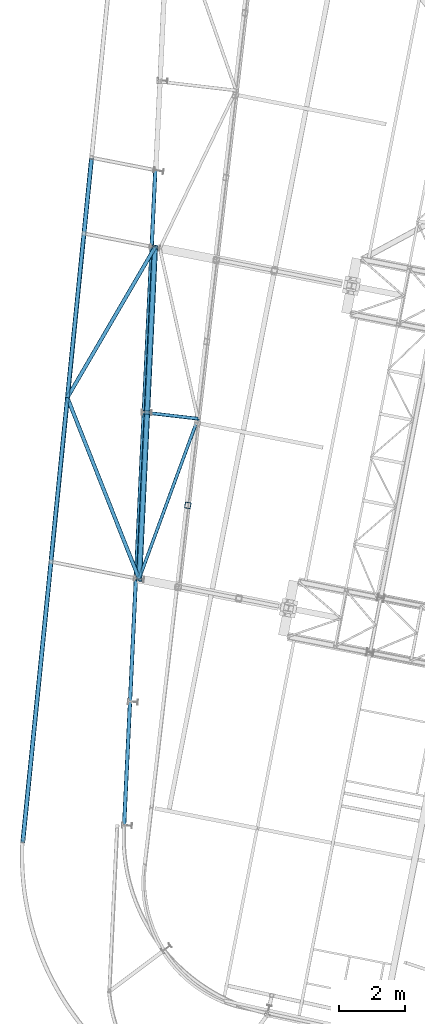
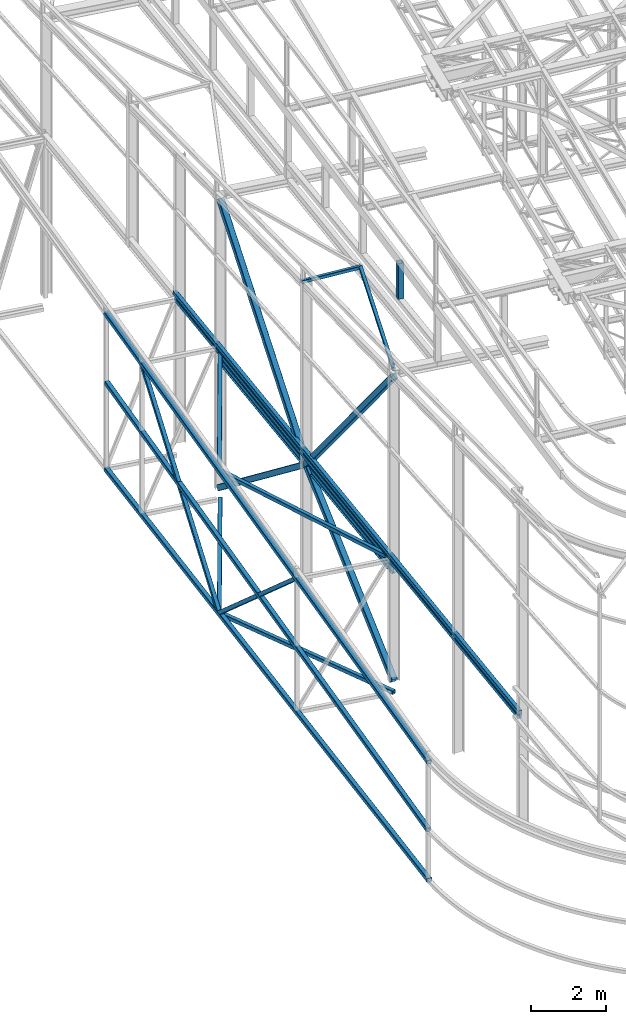
# One storey, part 42 of 215: 13 beams, 6 members, 19 elements without a shape of their own.
"""IFC2X3 building model written with IfcOpenShell, lengths in millimetres."""

from ifc_helpers import new_model, si_unit, frame, origin_with_axes, origin_2d_with_axis, place, context, subcontext, project, spatial, hollow_rectangle, i_section, extrude, clip, halfspace, material, type_object, element, aggregate, save


model = new_model("IFC2X3")

# Units and contexts
model_context = context("Model", 3, precision=1e-05, world=origin_with_axes())
body_context = subcontext(model_context, "Body", "Model", "MODEL_VIEW")
ifc_project = project(units=[si_unit("LENGTHUNIT", "METRE", prefix="MILLI"), si_unit("AREAUNIT", "SQUARE_METRE"), si_unit("VOLUMEUNIT", "CUBIC_METRE"), si_unit("MASSUNIT", "GRAM", prefix="KILO"), si_unit("TIMEUNIT", "SECOND"), si_unit("PLANEANGLEUNIT", "RADIAN"), si_unit("SOLIDANGLEUNIT", "STERADIAN"), si_unit("THERMODYNAMICTEMPERATUREUNIT", "DEGREE_CELSIUS"), si_unit("LUMINOUSINTENSITYUNIT", "LUMEN")], contexts=[model_context])

# Site, building, storey
site_placement = place(None, origin_with_axes())
site = spatial("IfcSite", under=ifc_project, at=site_placement, CompositionType="ELEMENT")
building_placement = place(site_placement, origin_with_axes())
building = spatial("IfcBuilding", under=site, at=building_placement, Name="Undefined", CompositionType="ELEMENT")
storey_placement = place(building_placement, origin_with_axes())
storey = spatial("IfcBuildingStorey", under=building, at=storey_placement, Name="Undefined", CompositionType="ELEMENT", Elevation=0.0)

# Assembly, beam
assembly_1_placement = place(storey_placement, origin_with_axes())
assembly_1 = element("IfcElementAssembly", 1, at=assembly_1_placement, inside=storey, Name="Steel Assembly", AssemblyPlace="NOTDEFINED", PredefinedType="RIGID_FRAME")
ifc_material_1 = material(Name="STEEL/S275JR")
beam_type_1 = type_object("IfcBeamType", Name="IPE240", PredefinedType="NOTDEFINED")
beam_1_placement = place(assembly_1_placement, frame((37702.395023757, 24081.8453887857, 3587.95465777144), z_axis=(-0.00276384299864547, -0.0580777589715231, 0.99830823651051), x_axis=(0.0474544460183351, 0.997179728385277, 0.0581434850224647)))
beam_1 = element("IfcBeam", 2, at=beam_1_placement, type_object=beam_type_1, material=ifc_material_1, Name="LISSE", ObjectType="IPE240", context=body_context, shape_type="SweptSolid", body=[
    extrude(i_section(OverallWidth=120.0, OverallDepth=240.0, WebThickness=6.199999809, FlangeThickness=9.800000191, FilletRadius=15.0, at=origin_2d_with_axis()), frame((10139.4064465862, -4.89457653130636e-14, 1.05020723293584e-12), z_axis=(-1.0, 0.0, 0.0), x_axis=(-6.93889390390723e-18, -1.0, -3.46944695195361e-18)), (0.0, 0.0, 1.0), 10139.4),
])
aggregate(assembly_1, [beam_1])

assembly_2_placement = place(storey_placement, origin_with_axes())
assembly_2 = element("IfcElementAssembly", 3, at=assembly_2_placement, inside=storey, Name="Steel Assembly", AssemblyPlace="NOTDEFINED", PredefinedType="RIGID_FRAME")
beam_type_2 = type_object("IfcBeamType", PredefinedType="NOTDEFINED")
beam_2_placement = place(assembly_2_placement, frame((37245.3550198465, 16578.5143878972, 3521.9789241944), z_axis=(-0.00279870499998948, -0.0583324129997587, 0.998293291995869), x_axis=(0.0475199150160084, 0.997161649335921, 0.0583995100196734)))
beam_2 = element("IfcBeam", 4, at=beam_2_placement, type_object=beam_type_2, material=ifc_material_1, Name="LISSE", context=body_context, shape_type="SweptSolid", body=[
    extrude(hollow_rectangle(XDim=120.0, YDim=120.0, WallThickness=5.0, InnerFilletRadius=5.0, OuterFilletRadius=10.0, at=origin_2d_with_axis()), frame((20005.568951686, -7.52018708256912e-12, 5.93563871329514e-13), z_axis=(-1.0, 0.0, 0.0), x_axis=(-6.93889390390723e-18, -1.0, -3.46944695195361e-18)), (0.0, 0.0, 1.0), 20005.6),
])
aggregate(assembly_2, [beam_2])

assembly_3_placement = place(storey_placement, origin_with_axes())
assembly_3 = element("IfcElementAssembly", 5, at=assembly_3_placement, inside=storey, Name="Steel Assembly", AssemblyPlace="NOTDEFINED", PredefinedType="RIGID_FRAME")
beam_3_placement = place(assembly_3_placement, frame((37244.8113143843, 16560.4333844096, 3680.22824974108), z_axis=(-0.00274567599890538, -0.0584633859767245, 0.998285777602509), x_axis=(0.0475021389989792, 0.997154973978577, 0.0585278109987426)))
beam_3 = element("IfcBeam", 6, at=beam_3_placement, type_object=beam_type_2, material=ifc_material_1, Name="LISSE", context=body_context, shape_type="SweptSolid", body=[
    extrude(hollow_rectangle(XDim=120.0, YDim=120.0, WallThickness=5.0, InnerFilletRadius=5.0, OuterFilletRadius=10.0, at=origin_2d_with_axis()), frame((20106.9030449298, -7.079022164791e-14, -1.39519666964917e-13), z_axis=(-1.0, 0.0, 0.0), x_axis=(-6.93889390390723e-18, -1.0, -3.46944695195361e-18)), (0.0, 0.0, 1.0), 20106.9),
])
aggregate(assembly_3, [beam_3])

assembly_4_placement = place(storey_placement, origin_with_axes())
assembly_4 = element("IfcElementAssembly", 7, at=assembly_4_placement, inside=storey, Name="Steel Assembly", AssemblyPlace="NOTDEFINED", PredefinedType="RIGID_FRAME")
beam_4_placement = place(assembly_4_placement, frame((35516.1942350972, 29589.8617573046, 4249.99303533058), z_axis=(0.86391141855058, -0.503643783737995, 0.0), x_axis=(0.502921216817885, 0.862671983687614, 0.0535471589806098)))
beam_4 = element("IfcBeam", 8, at=beam_4_placement, type_object=beam_type_2, material=ifc_material_1, context=body_context, shape_type="SweptSolid", body=[
    extrude(hollow_rectangle(XDim=120.0, YDim=120.0, WallThickness=5.0, InnerFilletRadius=5.0, OuterFilletRadius=10.0, at=origin_2d_with_axis()), frame((5302.3875490753, 5.28332760167328e-13, 3.76816913364588e-12), z_axis=(-1.0, 0.0, 0.0), x_axis=(-6.93889390390723e-18, -1.0, -3.46944695195361e-18)), (0.0, 0.0, 1.0), 5302.4),
])
aggregate(assembly_4, [beam_4])

assembly_5_placement = place(storey_placement, origin_with_axes())
assembly_5 = element("IfcElementAssembly", 9, at=assembly_5_placement, inside=storey, Name="Steel Assembly", AssemblyPlace="NOTDEFINED", PredefinedType="RIGID_FRAME")
beam_5_placement = place(assembly_5_placement, frame((37702.401727113, 24069.1858218941, 3944.51786385128), z_axis=(0.929752431547219, 0.368185301216702, 0.0), x_axis=(-0.367699031175966, 0.928524488444354, 0.0513779800245874)))
beam_5 = element("IfcBeam", 10, at=beam_5_placement, type_object=beam_type_2, material=ifc_material_1, context=body_context, shape_type="SweptSolid", body=[
    extrude(hollow_rectangle(XDim=120.0, YDim=120.0, WallThickness=5.0, InnerFilletRadius=5.0, OuterFilletRadius=10.0, at=origin_2d_with_axis()), frame((5945.64387417215, 0.0, 7.29676072179177e-12), z_axis=(-1.0, 0.0, 0.0), x_axis=(-6.93889390390723e-18, -1.0, -3.46944695195361e-18)), (0.0, 0.0, 1.0), 5945.6),
])
aggregate(assembly_5, [beam_5])

assembly_6_placement = place(storey_placement, origin_with_axes())
assembly_6 = element("IfcElementAssembly", 11, at=assembly_6_placement, inside=storey, Name="Steel Assembly", AssemblyPlace="NOTDEFINED", PredefinedType="RIGID_FRAME")
beam_6_placement = place(assembly_6_placement, frame((35516.1942349543, 29589.8617572934, -375.378507628906), z_axis=(0.86391141855058, -0.503643783737995, 0.0), x_axis=(0.5036437841731, 0.863911418296922, 0.0)))
beam_6 = element("IfcBeam", 12, at=beam_6_placement, type_object=beam_type_2, material=ifc_material_1, context=body_context, shape_type="SweptSolid", body=[
    extrude(hollow_rectangle(XDim=120.0, YDim=120.0, WallThickness=5.0, InnerFilletRadius=5.0, OuterFilletRadius=10.0, at=origin_2d_with_axis()), frame((5294.78032861947, 0.0, -5.87838703116569e-13), z_axis=(-1.0, 0.0, 0.0), x_axis=(-6.93889390390723e-18, -1.0, -3.46944695195361e-18)), (0.0, 0.0, 1.0), 5294.8),
])
aggregate(assembly_6, [beam_6])

assembly_7_placement = place(storey_placement, origin_with_axes())
assembly_7 = element("IfcElementAssembly", 13, at=assembly_7_placement, inside=storey, Name="Steel Assembly", AssemblyPlace="NOTDEFINED", PredefinedType="RIGID_FRAME")
beam_7_placement = place(assembly_7_placement, frame((37702.4017271117, 24069.1858218863, -375.378507632738), z_axis=(0.929752431547219, 0.368185301216702, 0.0), x_axis=(-0.36818530087438, 0.92975243168278, 0.0)))
beam_7 = element("IfcBeam", 14, at=beam_7_placement, type_object=beam_type_2, material=ifc_material_1, context=body_context, shape_type="SweptSolid", body=[
    extrude(hollow_rectangle(XDim=120.0, YDim=120.0, WallThickness=5.0, InnerFilletRadius=5.0, OuterFilletRadius=10.0, at=origin_2d_with_axis()), frame((5937.79133878312, 5.6843418860808e-14, 0.0), z_axis=(-1.0, 0.0, 0.0), x_axis=(-6.93889390390723e-18, -1.0, -3.46944695195361e-18)), (0.0, 0.0, 1.0), 5937.8),
])
aggregate(assembly_7, [beam_7])

assembly_8_placement = place(storey_placement, origin_with_axes())
assembly_8 = element("IfcElementAssembly", 15, at=assembly_8_placement, inside=storey, Name="Steel Assembly", AssemblyPlace="NOTDEFINED", PredefinedType="RIGID_FRAME")
beam_type_3 = type_object("IfcBeamType", PredefinedType="NOTDEFINED")
beam_8_placement = place(assembly_8_placement, frame((37784.1180891928, 29146.3516959011, 9870.42381029641), z_axis=(0.115203788960212, 0.992088860657365, -0.0498776459827747), x_axis=(0.993325216792512, -0.115347360975905, -6.30000004858045e-08)))
beam_8 = element("IfcBeam", 16, at=beam_8_placement, type_object=beam_type_3, material=ifc_material_1, context=body_context, shape_type="SweptSolid", body=[
    extrude(hollow_rectangle(XDim=100.0, YDim=100.0, WallThickness=5.0, InnerFilletRadius=5.0, OuterFilletRadius=10.0, at=origin_2d_with_axis()), frame((1716.90167054726, 1.3722649592389e-15, 4.55212574664582e-15), z_axis=(-1.0, 0.0, 0.0), x_axis=(-6.93889390390723e-18, -1.0, -3.46944695195361e-18)), (0.0, 0.0, 1.0), 1716.9),
])
aggregate(assembly_8, [beam_8])

assembly_9_placement = place(storey_placement, origin_with_axes())
assembly_9 = element("IfcElementAssembly", 17, at=assembly_9_placement, inside=storey, Name="Steel Assembly", AssemblyPlace="NOTDEFINED", PredefinedType="RIGID_FRAME")
beam_9_placement = place(assembly_9_placement, frame((39489.5598133644, 28948.3116191889, 9870.42370259191), z_axis=(0.938944613111395, -0.343871057040797, 0.0116494480013822), x_axis=(-0.344020222019175, -0.937708919052267, 0.0484981440027034)))
beam_9 = element("IfcBeam", 18, at=beam_9_placement, type_object=beam_type_3, material=ifc_material_1, context=body_context, shape_type="SweptSolid", body=[
    extrude(hollow_rectangle(XDim=100.0, YDim=100.0, WallThickness=5.0, InnerFilletRadius=5.0, OuterFilletRadius=10.0, at=origin_2d_with_axis()), frame((5191.06870020418, -1.78296912858725e-12, 4.44730936006799e-12), z_axis=(-1.0, 0.0, 0.0), x_axis=(-6.93889390390723e-18, -1.0, -3.46944695195361e-18)), (0.0, 0.0, 1.0), 5191.1),
])
aggregate(assembly_9, [beam_9])

# Assembly, member
assembly_10_placement = place(storey_placement, origin_with_axes())
assembly_10 = element("IfcElementAssembly", 19, at=assembly_10_placement, inside=storey, Name="Steel Assembly", AssemblyPlace="NOTDEFINED", PredefinedType="RIGID_FRAME")
member_type_1 = type_object("IfcMemberType", PredefinedType="NOTDEFINED")
member_1_placement = place(assembly_10_placement, frame((35516.2354425136, 29590.2715087666, -380.000192254633), z_axis=(-0.994981508328456, 0.10005897303303, 7.60000000037375e-08), x_axis=(-0.0757336799789731, -0.753092482790908, 0.653541216818548)))
member_1 = element("IfcMember", 20, at=member_1_placement, type_object=member_type_1, material=ifc_material_1, Name="LISSE", context=body_context, shape_type="SweptSolid", body=[
    extrude(hollow_rectangle(XDim=120.0, YDim=120.0, WallThickness=5.0, InnerFilletRadius=5.0, OuterFilletRadius=10.0, at=origin_2d_with_axis()), frame((6634.36296563795, -7.36562251817169e-13, 1.32184024394049e-13), z_axis=(-1.0, 0.0, 0.0), x_axis=(-6.93889390390723e-18, -1.0, -3.46944695195361e-18)), (0.0, 0.0, 1.0), 6634.4),
])
aggregate(assembly_10, [member_1])

assembly_11_placement = place(storey_placement, origin_with_axes())
assembly_11 = element("IfcElementAssembly", 21, at=assembly_11_placement, inside=storey, Name="Steel Assembly", AssemblyPlace="NOTDEFINED", PredefinedType="RIGID_FRAME")
member_2_placement = place(assembly_11_placement, frame((36018.6780823978, 34586.5397305908, 4544.18726639941), z_axis=(-0.994978168370554, 0.100092174037274, -3.40950000126771e-05), x_axis=(-0.0714409600094574, -0.710405871094048, -0.700156902092691)))
member_2 = element("IfcMember", 22, at=member_2_placement, type_object=member_type_1, material=ifc_material_1, Name="LISSE", context=body_context, shape_type="SweptSolid", body=[
    extrude(hollow_rectangle(XDim=120.0, YDim=120.0, WallThickness=5.0, InnerFilletRadius=5.0, OuterFilletRadius=10.0, at=origin_2d_with_axis()), frame((7032.97709762473, -7.80817310544438e-13, -3.54609552005987e-12), z_axis=(-1.0, 0.0, 0.0), x_axis=(-6.93889390390723e-18, -1.0, -3.46944695195361e-18)), (0.0, 0.0, 1.0), 7033.0),
])
aggregate(assembly_11, [member_2])

# Assembly, beam
assembly_12_placement = place(storey_placement, origin_with_axes())
assembly_12 = element("IfcElementAssembly", 23, at=assembly_12_placement, inside=storey, Name="Steel Assembly", AssemblyPlace="NOTDEFINED", PredefinedType="RIGID_FRAME")
beam_type_4 = type_object("IfcBeamType", PredefinedType="NOTDEFINED")
beam_10_placement = place(assembly_12_placement, frame((39183.2042802955, 26310.2501751328, 11749.0824556142), z_axis=(-0.981422412140383, 0.191859451027444, 0.0), x_axis=(0.0, 0.0, -1.0)))
beam_10 = element("IfcBeam", 24, at=beam_10_placement, type_object=beam_type_4, material=ifc_material_1, Name="MONTANT", context=body_context, shape_type="Clipping", body=[
    clip(extrude(hollow_rectangle(XDim=180.0, YDim=180.0, WallThickness=8.0, InnerFilletRadius=12.0, OuterFilletRadius=20.0, at=origin_2d_with_axis()), frame((1166.84780650014, 0.0, 0.0), z_axis=(-1.0, 0.0, 0.0), x_axis=(-6.93889390390723e-18, -1.0, -3.46944695195361e-18)), (0.0, 0.0, 1.0), 1166.8), halfspace(frame((1169.02037938846, -133.691974753034, 100.630765854497), z_axis=(-0.99875033817135, -0.0498277907891155, 0.00386694552461437), x_axis=(0.0, -0.0773735506072624, -0.997002173350904)), True)),
])
aggregate(assembly_12, [beam_10])

assembly_13_placement = place(storey_placement, origin_with_axes())
assembly_13 = element("IfcElementAssembly", 25, at=assembly_13_placement, inside=storey, Name="Steel Assembly", AssemblyPlace="NOTDEFINED", PredefinedType="RIGID_FRAME")
beam_type_5 = type_object("IfcBeamType", PredefinedType="NOTDEFINED")
beam_11_placement = place(assembly_13_placement, frame((34164.6279979949, 16103.0440502901, 1226.42910362387), z_axis=(-0.00585299100114405, -0.058084468011355, 0.998294514195174), x_axis=(0.0998883439531066, 0.993284579533696, 0.0583786159725937)))
beam_11 = element("IfcBeam", 26, at=beam_11_placement, type_object=beam_type_5, material=ifc_material_1, Name="LISSE", context=body_context, shape_type="SweptSolid", body=[
    extrude(hollow_rectangle(XDim=140.0, YDim=140.0, WallThickness=8.0, InnerFilletRadius=12.0, OuterFilletRadius=20.0, at=origin_2d_with_axis()), frame((20885.9053007552, 7.27560158180373e-12, -3.98160303286319e-14), z_axis=(-1.0, 0.0, 0.0), x_axis=(-6.93889390390723e-18, -1.0, -3.46944695195361e-18)), (0.0, 0.0, 1.0), 20885.9),
])
aggregate(assembly_13, [beam_11])

assembly_14_placement = place(storey_placement, origin_with_axes())
assembly_14 = element("IfcElementAssembly", 27, at=assembly_14_placement, inside=storey, Name="Steel Assembly", AssemblyPlace="NOTDEFINED", PredefinedType="RIGID_FRAME")
beam_12_placement = place(assembly_14_placement, frame((34158.6788035481, 16043.8873792673, -380.000192697401), z_axis=(0.0, 0.0, 1.0), x_axis=(0.100060559973715, 0.994981348738631, -3.79999999887618e-08)))
beam_12 = element("IfcBeam", 28, at=beam_12_placement, type_object=beam_type_5, material=ifc_material_1, Name="LISSE", context=body_context, shape_type="SweptSolid", body=[
    extrude(hollow_rectangle(XDim=140.0, YDim=140.0, WallThickness=8.0, InnerFilletRadius=12.0, OuterFilletRadius=20.0, at=origin_2d_with_axis()), frame((20945.2237454623, -2.21015460189945e-13, 0.0), z_axis=(-1.0, 0.0, 0.0), x_axis=(-6.93889390390723e-18, -1.0, -3.46944695195361e-18)), (0.0, 0.0, 1.0), 20945.2),
])
aggregate(assembly_14, [beam_12])

assembly_15_placement = place(storey_placement, origin_with_axes())
assembly_15 = element("IfcElementAssembly", 29, at=assembly_15_placement, inside=storey, Name="Steel Assembly", AssemblyPlace="NOTDEFINED", PredefinedType="RIGID_FRAME")
beam_13_placement = place(assembly_15_placement, frame((34159.0884629908, 16047.9608884652, 3452.64841673588), z_axis=(-0.00585213200252552, -0.0581915090251133, 0.998288285430819), x_axis=(0.099887760989917, 0.993278377899736, 0.0584850339940963)))
beam_13 = element("IfcBeam", 30, at=beam_13_placement, type_object=beam_type_5, material=ifc_material_1, Name="LISSE", context=body_context, shape_type="SweptSolid", body=[
    extrude(hollow_rectangle(XDim=140.0, YDim=140.0, WallThickness=8.0, InnerFilletRadius=12.0, OuterFilletRadius=20.0, at=origin_2d_with_axis()), frame((20993.6087199957, 2.2296368648553e-13, -4.54747350886464e-13), z_axis=(-1.0, 0.0, 0.0), x_axis=(-6.93889390390723e-18, -1.0, -3.46944695195361e-18)), (0.0, 0.0, 1.0), 20993.6),
])
aggregate(assembly_15, [beam_13])

# Assembly, member
assembly_16_placement = place(storey_placement, origin_with_axes())
assembly_16 = element("IfcElementAssembly", 31, at=assembly_16_placement, inside=storey, Name="Steel Assembly", AssemblyPlace="NOTDEFINED", PredefinedType="RIGID_FRAME")
ifc_material_2 = material(Name="STEEL/S235JR")
member_type_2 = type_object("IfcMemberType", PredefinedType="NOTDEFINED")
member_3_placement = place(assembly_16_placement, frame((37943.3661519106, 29139.9230198867, 3882.91919967125), z_axis=(-0.998881412338171, 0.0472845780160069, 0.000304577000102995), x_axis=(0.0321051670081043, 0.673460930169995, 0.738525310186419)))
member_3 = element("IfcMember", 32, at=member_3_placement, type_object=member_type_2, material=ifc_material_2, context=body_context, shape_type="SweptSolid", body=[
    extrude(hollow_rectangle(XDim=180.0, YDim=180.0, WallThickness=8.0, InnerFilletRadius=12.0, OuterFilletRadius=20.0, at=origin_2d_with_axis()), frame((7460.20993590066, 4.05210364906043e-12, 7.48174763322383e-15), z_axis=(-1.0, 0.0, 0.0), x_axis=(-6.93889390390723e-18, -1.0, -3.46944695195361e-18)), (0.0, 0.0, 1.0), 7460.2),
])
aggregate(assembly_16, [member_3])

assembly_17_placement = place(storey_placement, origin_with_axes())
assembly_17 = element("IfcElementAssembly", 33, at=assembly_17_placement, inside=storey, Name="Steel Assembly", AssemblyPlace="NOTDEFINED", PredefinedType="RIGID_FRAME")
member_4_placement = place(assembly_17_placement, frame((37943.3658915526, 29139.9211546268, 3882.88131192819), z_axis=(-0.998852011746622, 0.0479011859878479, 0.000367437999907011), x_axis=(0.0376932050019723, 0.790679051041374, -0.611069440031976)))
member_4 = element("IfcMember", 34, at=member_4_placement, type_object=member_type_2, material=ifc_material_2, context=body_context, shape_type="SweptSolid", body=[
    extrude(hollow_rectangle(XDim=180.0, YDim=180.0, WallThickness=8.0, InnerFilletRadius=12.0, OuterFilletRadius=20.0, at=origin_2d_with_axis()), frame((6354.23662634172, 2.93251682644361e-12, 1.73954248157858e-14), z_axis=(-1.0, 0.0, 0.0), x_axis=(-6.93889390390723e-18, -1.0, -3.46944695195361e-18)), (0.0, 0.0, 1.0), 6354.2),
])
aggregate(assembly_17, [member_4])

assembly_18_placement = place(storey_placement, origin_with_axes())
assembly_18 = element("IfcElementAssembly", 35, at=assembly_18_placement, inside=storey, Name="Steel Assembly", AssemblyPlace="NOTDEFINED", PredefinedType="RIGID_FRAME")
member_5_placement = place(assembly_18_placement, frame((37702.4017271118, 24069.185821887, 0.00149219693048508), z_axis=(-0.998885731008418, 0.0471928770003989, 0.000358815000003023), x_axis=(0.0377025079878554, 0.793393097744444, 0.607540873804308)))
member_5 = element("IfcMember", 36, at=member_5_placement, type_object=member_type_2, material=ifc_material_2, context=body_context, shape_type="SweptSolid", body=[
    extrude(hollow_rectangle(XDim=180.0, YDim=180.0, WallThickness=8.0, InnerFilletRadius=12.0, OuterFilletRadius=20.0, at=origin_2d_with_axis()), frame((6391.2040734384, 1.46420630767539e-12, 1.76698612201113e-14), z_axis=(-1.0, 0.0, 0.0), x_axis=(-6.93889390390723e-18, -1.0, -3.46944695195361e-18)), (0.0, 0.0, 1.0), 6391.2),
])
aggregate(assembly_18, [member_5])

assembly_19_placement = place(storey_placement, origin_with_axes())
assembly_19 = element("IfcElementAssembly", 37, at=assembly_19_placement, inside=storey, Name="Steel Assembly", AssemblyPlace="NOTDEFINED", PredefinedType="RIGID_FRAME")
member_6_placement = place(assembly_19_placement, frame((37702.4017271136, 24069.1858219049, 9892.08230787454), z_axis=(-0.998855868034768, 0.0478211790016633, 0.000299552000010831), x_axis=(0.0306319110027556, 0.644603371057996, -0.763903253068729)))
member_6 = element("IfcMember", 38, at=member_6_placement, type_object=member_type_2, material=ifc_material_2, context=body_context, shape_type="SweptSolid", body=[
    extrude(hollow_rectangle(XDim=180.0, YDim=180.0, WallThickness=8.0, InnerFilletRadius=12.0, OuterFilletRadius=20.0, at=origin_2d_with_axis()), frame((7866.4424711612, 8.73350555337237e-13, -5.28786469051843e-14), z_axis=(-1.0, 0.0, 0.0), x_axis=(-6.93889390390723e-18, -1.0, -3.46944695195361e-18)), (0.0, 0.0, 1.0), 7866.4),
])
aggregate(assembly_19, [member_6])

save(model, "model.ifc")
